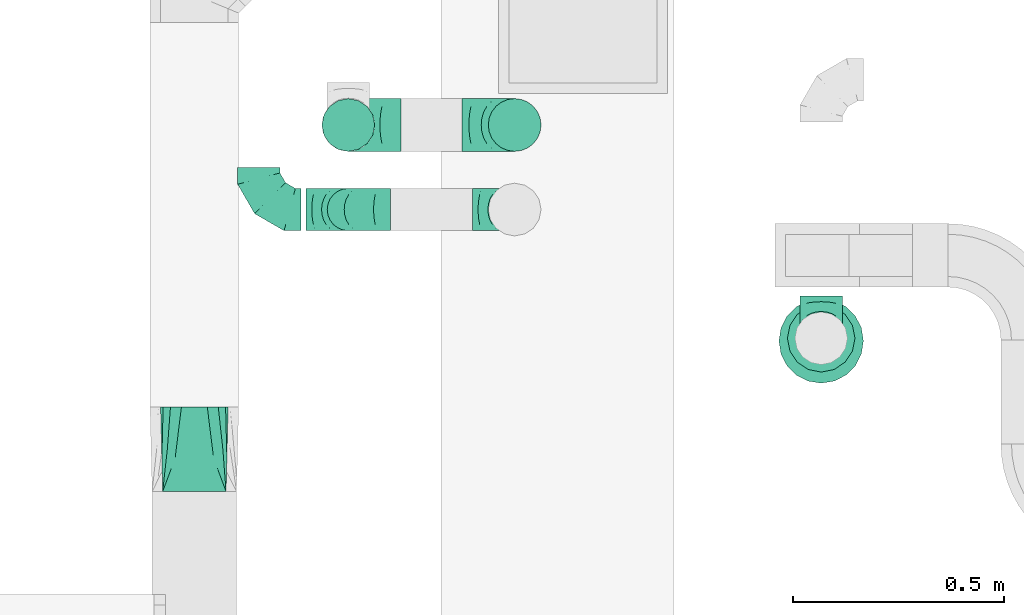
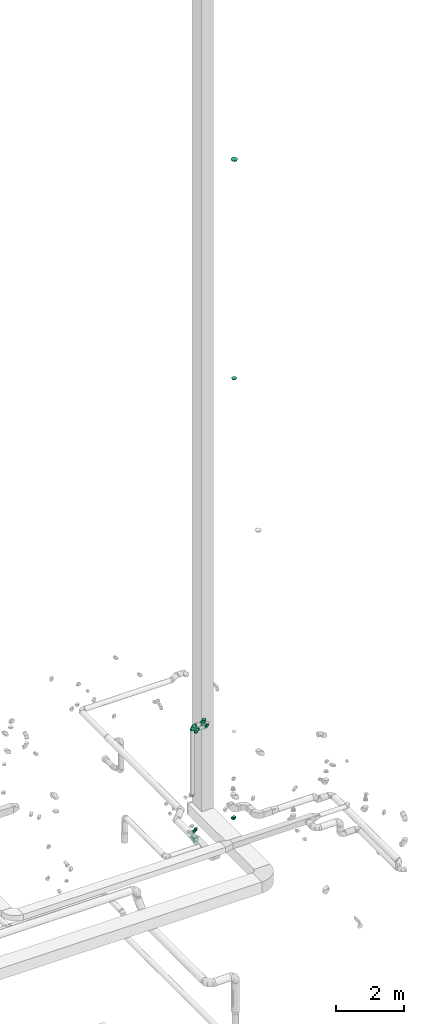
# One storey, part 73 of 97: 11 flow fittings.
"""IFC2X3 building model written with IfcOpenShell, lengths in millimetres."""

import ifcopenshell
import ifcopenshell.guid

model = None  # the IFC model being written
_history = None  # IfcOwnerHistory: only IFC2X3 demands one
_inside = {}  # id of a spatial element -> (the spatial element, [elements in it])
_under = {}  # id of a project, library or spatial element -> (it, [spatial elements below it])
_declared = {}  # id of a project -> (the project, [libraries it declares])
_typed = {}  # id of a type object -> (the type object, [elements of that type])
_made_of = {}  # id of a material, layer set ... -> (it, [elements and type objects made of it])


def new_model(schema):
    """Start an empty IFC model of exactly this schema.

    Asked for "IFC4X3", IfcOpenShell would pick the latest addendum, in which some entities
    have other attributes; the version numbers below select the first issue.
    IFC2X3 requires an IfcOwnerHistory on every rooted entity: one is made here for all.
    """
    global model, _history
    if schema == "IFC4X3":
        model = ifcopenshell.file(schema_version=(4, 3, 0, 0))
    else:
        model = ifcopenshell.file(schema=schema)
    _inside.clear()
    _under.clear()
    _declared.clear()
    _typed.clear()
    _made_of.clear()
    _history = None
    if model.schema == "IFC2X3":
        org = make("IfcOrganization", Name="unknown")
        user = make(
            "IfcPersonAndOrganization",
            ThePerson=make("IfcPerson", FamilyName="unknown"),
            TheOrganization=org,
        )
        app = make(
            "IfcApplication",
            ApplicationDeveloper=org,
            Version="unknown",
            ApplicationFullName="unknown",
            ApplicationIdentifier="unknown",
        )
        _history = make(
            "IfcOwnerHistory",
            OwningUser=user,
            OwningApplication=app,
            ChangeAction="ADDED",
            CreationDate=0,
        )
    return model


def make(cls, **values):
    """One entity of the class cls with the attributes given. An attribute that is None is left unset."""
    return model.create_entity(
        cls, **{name: value for name, value in values.items() if value is not None}
    )


def entity(cls, *values):
    """Any entity or typed value of the class cls, its attributes in the order of the schema. None: left unset."""
    e = model.create_entity(cls)
    for i, value in enumerate(values):
        if value is not None:
            e[i] = value
    return e


def rooted(cls, **values):
    """An entity with a GlobalId (a new one), such as an element, a storey or a relation."""
    return make(cls, GlobalId=ifcopenshell.guid.new(), OwnerHistory=_history, **values)


def si_unit(unit_type, name, prefix=None):
    """IfcSIUnit, for example si_unit("LENGTHUNIT", "METRE", prefix="MILLI")."""
    return make("IfcSIUnit", UnitType=unit_type, Prefix=prefix, Name=name)


def converted_unit(unit_type, name, factor, base, dimensions=None, offset=None):
    """IfcConversionBasedUnit, such as the inch: factor (a typed value) times the base unit."""
    return make(
        "IfcConversionBasedUnit"
        if offset is None
        else "IfcConversionBasedUnitWithOffset",
        ConversionOffset=offset,
        Dimensions=None
        if dimensions is None
        else entity("IfcDimensionalExponents", *dimensions),
        UnitType=unit_type,
        Name=name,
        ConversionFactor=make(
            "IfcMeasureWithUnit", ValueComponent=factor, UnitComponent=base
        ),
    )


def derived_unit(unit_type, elements):
    """IfcDerivedUnit: a product of units, each with its exponent."""
    return make(
        "IfcDerivedUnit",
        Elements=[
            make("IfcDerivedUnitElement", Unit=unit, Exponent=power)
            for unit, power in elements
        ],
        UnitType=unit_type,
    )


def assignment(units):
    """IfcUnitAssignment: the units of a project."""
    return None if units is None else make("IfcUnitAssignment", Units=units)


def point(xyz):
    """IfcCartesianPoint."""
    return None if xyz is None else make("IfcCartesianPoint", Coordinates=xyz)


def direction(xyz):
    """IfcDirection."""
    return None if xyz is None else make("IfcDirection", DirectionRatios=xyz)


def frame(location, z_axis=None, x_axis=None):
    """IfcAxis2Placement3D, a coordinate frame: its origin and axes. An axis left out is left unset."""
    return make(
        "IfcAxis2Placement3D",
        Location=point(location),
        Axis=direction(z_axis),
        RefDirection=direction(x_axis),
    )


def origin():
    """The frame at (0, 0, 0) with its axes left unset."""
    return frame((0.0, 0.0, 0.0))


def place(relative_to, where):
    """IfcLocalPlacement: puts the frame where relative to a parent placement (None: the world)."""
    return make(
        "IfcLocalPlacement", PlacementRelTo=relative_to, RelativePlacement=where
    )


def context(
    kind, dimensions, precision=None, world=None, true_north=None, identifier=None
):
    """IfcGeometricRepresentationContext, for example the 3D "Model" context."""
    return make(
        "IfcGeometricRepresentationContext",
        ContextIdentifier=identifier,
        ContextType=kind,
        CoordinateSpaceDimension=dimensions,
        Precision=precision,
        WorldCoordinateSystem=world,
        TrueNorth=true_north,
    )


def subcontext(parent, identifier, kind, view, scale=None):
    """IfcGeometricRepresentationSubContext, for example "Body" below "Model"."""
    return make(
        "IfcGeometricRepresentationSubContext",
        ContextIdentifier=identifier,
        ContextType=kind,
        ParentContext=parent,
        TargetScale=scale,
        TargetView=view,
    )


def project(units=None, contexts=None):
    """IfcProject with its units and contexts."""
    return rooted(
        "IfcProject",
        Name="project",
        RepresentationContexts=contexts,
        UnitsInContext=assignment(units),
    )


def spatial(cls, under=None, at=None, **own):
    """A site, building, storey or space (cls), placed at a placement, below another one or the project."""
    s = rooted(cls, ObjectPlacement=at, **own)
    if under is not None:
        _under.setdefault(under.id(), (under, []))[1].append(s)
    return s


def faces_of(points, faces, orient=None, outer=None):
    """IfcFace entities. A face is a list of loops; a loop is a list of indices into points, from 0.

    orient and outer hold one flag for each loop. By default every Orientation is true, the
    first loop of a face is its IfcFaceOuterBound and the others are IfcFaceBound.
    """
    made = []
    for i, loops in enumerate(faces):
        bounds = []
        for j, loop in enumerate(loops):
            is_outer = j == 0 if outer is None else outer[i][j]
            bounds.append(
                make(
                    "IfcFaceOuterBound" if is_outer else "IfcFaceBound",
                    Bound=make("IfcPolyLoop", Polygon=[points[k] for k in loop]),
                    Orientation=True if orient is None else orient[i][j],
                )
            )
        made.append(make("IfcFace", Bounds=bounds))
    return made


def faceted_brep(points, faces, orient=None, outer=None, voids=None):
    """IfcFacetedBrep: a solid bounded by flat faces; with voids (closed shells), ...WithVoids."""
    shared = [point(p) for p in points]
    hull = make("IfcClosedShell", CfsFaces=faces_of(shared, faces, orient, outer))
    if voids is None:
        return make("IfcFacetedBrep", Outer=hull)
    return make(
        "IfcFacetedBrepWithVoids",
        Outer=hull,
        Voids=[
            make(cls, CfsFaces=faces_of(shared, fs, o, b)) for cls, fs, o, b in voids
        ],
    )


def shape(context_of_items, identifier, shape_type, items):
    """IfcShapeRepresentation: the items that make up one representation, for example the "Body"."""
    return make(
        "IfcShapeRepresentation",
        ContextOfItems=context_of_items,
        RepresentationIdentifier=identifier,
        RepresentationType=shape_type,
        Items=items,
    )


def source(mapping_origin, context_of_items, identifier, shape_type, items):
    """IfcRepresentationMap: a shape defined once, which mapped items show again and again."""
    return make(
        "IfcRepresentationMap",
        MappingOrigin=mapping_origin,
        MappedRepresentation=shape(context_of_items, identifier, shape_type, items),
    )


def transform(
    local_origin,
    x_axis=None,
    y_axis=None,
    z_axis=None,
    scale=None,
    scale2=None,
    scale3=None,
    uniform=True,
):
    """IfcCartesianTransformationOperator3D, or its non-uniform kind. x_axis, y_axis, z_axis: its Axis1, 2, 3."""
    if uniform:
        return make(
            "IfcCartesianTransformationOperator3D",
            Axis1=direction(x_axis),
            Axis2=direction(y_axis),
            LocalOrigin=point(local_origin),
            Scale=scale,
            Axis3=direction(z_axis),
        )
    return make(
        "IfcCartesianTransformationOperator3DnonUniform",
        Axis1=direction(x_axis),
        Axis2=direction(y_axis),
        LocalOrigin=point(local_origin),
        Scale=scale,
        Axis3=direction(z_axis),
        Scale2=scale2,
        Scale3=scale3,
    )


def mapped(mapping_source, mapping_target):
    """IfcMappedItem: shows the shape of a source again, moved by a transform."""
    return make(
        "IfcMappedItem", MappingSource=mapping_source, MappingTarget=mapping_target
    )


def material(Name=None, Category=None):
    """IfcMaterial."""
    return make("IfcMaterial", Name=Name, Category=Category)


def made_of(thing, what):
    """Note that an element or type object is made of a material, layer set ...; save() writes the relation."""
    if what is not None:
        _made_of.setdefault(what.id(), (what, []))[1].append(thing)
    return thing


def type_object(cls, material=None, **own):
    """A type object (cls), such as IfcWallType, which elements share."""
    return made_of(rooted(cls, **own), material)


def type_shapes(of_type, sources):
    """Give a type object the sources (RepresentationMaps) that its elements show as mapped items."""
    of_type.RepresentationMaps = sources


def element(
    cls,
    number,
    at=None,
    inside=None,
    cuts=None,
    type_object=None,
    material=None,
    context=None,
    identifier="Body",
    shape_type=None,
    held_by="IfcProductDefinitionShape",
    body=None,
    shapes=None,
    **own,
):
    """One element of the class cls, such as IfcWall. Its Tag is "e" and its number.

    at: its placement. inside: the storey or other place that contains it. cuts: it is an
    opening in that element (IfcRelVoidsElement). A single representation is given by context,
    identifier, shape_type and body (its items); several are given by shapes. held_by: the class
    of the entity that holds the representations. save() writes the other relations.
    """
    e = rooted(cls, Tag="e%d" % number, ObjectPlacement=at, **own)
    if body is not None:
        shapes = [shape(context, identifier, shape_type, body)]
    if shapes is not None:
        e.Representation = make(held_by, Representations=shapes)
    if inside is not None:
        _inside.setdefault(inside.id(), (inside, []))[1].append(e)
    if cuts is not None:
        rooted(
            "IfcRelVoidsElement", RelatingBuildingElement=cuts, RelatedOpeningElement=e
        )
    if type_object is not None:
        _typed.setdefault(type_object.id(), (type_object, []))[1].append(e)
    return made_of(e, material)


def aggregate(whole, parts):
    """IfcRelAggregates: a whole, such as a stair, and the parts it consists of."""
    return rooted("IfcRelAggregates", RelatingObject=whole, RelatedObjects=parts)


def save(model, path):
    """Write the relations noted so far, then the file.

    IfcRelAggregates (storeys below a building ...), IfcRelContainedInSpatialStructure (elements
    in a storey), IfcRelDefinesByType, IfcRelAssociatesMaterial and IfcRelDeclares: one each for
    every whole, place, type object, material and project.
    """
    for whole, parts in _under.values():
        aggregate(whole, parts)
    for where, things in _inside.values():
        rooted(
            "IfcRelContainedInSpatialStructure",
            RelatedElements=things,
            RelatingStructure=where,
        )
    for kind, things in _typed.values():
        rooted("IfcRelDefinesByType", RelatedObjects=things, RelatingType=kind)
    for what, things in _made_of.values():
        rooted("IfcRelAssociatesMaterial", RelatedObjects=things, RelatingMaterial=what)
    for by, libraries in _declared.values():
        rooted("IfcRelDeclares", RelatingContext=by, RelatedDefinitions=libraries)
    model.write(path)


model = new_model("IFC2X3")

# Units and contexts
model_context = context("Model", 3, precision=0.01, world=origin(), true_north=direction((6.12303176911189e-17, 1.0)))
body_context = subcontext(model_context, "Body", "Model", "MODEL_VIEW")
ifc_project = project(units=[si_unit("LENGTHUNIT", "METRE", prefix="MILLI"), si_unit("AREAUNIT", "SQUARE_METRE"), si_unit("VOLUMEUNIT", "CUBIC_METRE"), converted_unit("PLANEANGLEUNIT", "DEGREE", entity("IfcRatioMeasure", 0.0174532925199433), si_unit("PLANEANGLEUNIT", "RADIAN"), dimensions=[0, 0, 0, 0, 0, 0, 0]), si_unit("MASSUNIT", "GRAM", prefix="KILO"), derived_unit("MASSDENSITYUNIT", [(si_unit("MASSUNIT", "GRAM", prefix="KILO"), 1), (si_unit("LENGTHUNIT", "METRE"), -3)]), derived_unit("MOMENTOFINERTIAUNIT", [(si_unit("LENGTHUNIT", "METRE"), 4)]), si_unit("TIMEUNIT", "SECOND"), si_unit("FREQUENCYUNIT", "HERTZ"), si_unit("THERMODYNAMICTEMPERATUREUNIT", "DEGREE_CELSIUS"), derived_unit("THERMALTRANSMITTANCEUNIT", [(si_unit("MASSUNIT", "GRAM", prefix="KILO"), 1), (si_unit("THERMODYNAMICTEMPERATUREUNIT", "KELVIN"), -1), (si_unit("TIMEUNIT", "SECOND"), -3)]), derived_unit("VOLUMETRICFLOWRATEUNIT", [(si_unit("LENGTHUNIT", "METRE"), 3), (si_unit("TIMEUNIT", "SECOND"), -1)]), derived_unit("MASSFLOWRATEUNIT", [(si_unit("MASSUNIT", "GRAM", prefix="KILO"), 1), (si_unit("TIMEUNIT", "SECOND"), -1)]), derived_unit("ROTATIONALFREQUENCYUNIT", [(si_unit("TIMEUNIT", "SECOND"), -1)]), si_unit("ELECTRICCURRENTUNIT", "AMPERE"), si_unit("ELECTRICVOLTAGEUNIT", "VOLT"), si_unit("POWERUNIT", "WATT"), si_unit("FORCEUNIT", "NEWTON", prefix="KILO"), si_unit("ILLUMINANCEUNIT", "LUX"), si_unit("LUMINOUSFLUXUNIT", "LUMEN"), si_unit("LUMINOUSINTENSITYUNIT", "CANDELA"), derived_unit("USERDEFINED", [(si_unit("MASSUNIT", "GRAM", prefix="KILO"), -1), (si_unit("LENGTHUNIT", "METRE"), -2), (si_unit("TIMEUNIT", "SECOND"), 3), (si_unit("LUMINOUSFLUXUNIT", "LUMEN"), 1)]), derived_unit("LINEARVELOCITYUNIT", [(si_unit("LENGTHUNIT", "METRE"), 1), (si_unit("TIMEUNIT", "SECOND"), -1)]), si_unit("PRESSUREUNIT", "PASCAL"), derived_unit("USERDEFINED", [(si_unit("LENGTHUNIT", "METRE"), -2), (si_unit("MASSUNIT", "GRAM", prefix="KILO"), 1), (si_unit("TIMEUNIT", "SECOND"), -2)]), derived_unit("LINEARFORCEUNIT", [(si_unit("MASSUNIT", "GRAM", prefix="KILO"), 1), (si_unit("LENGTHUNIT", "METRE"), 1), (si_unit("TIMEUNIT", "SECOND"), -2), (si_unit("LENGTHUNIT", "METRE"), -1)]), derived_unit("PLANARFORCEUNIT", [(si_unit("MASSUNIT", "GRAM", prefix="KILO"), 1), (si_unit("LENGTHUNIT", "METRE"), 1), (si_unit("TIMEUNIT", "SECOND"), -2), (si_unit("LENGTHUNIT", "METRE"), -2)])], contexts=[model_context])

# Site, building, storey
site_placement = place(None, origin())
site = spatial("IfcSite", under=ifc_project, at=site_placement, CompositionType="ELEMENT")
building_placement = place(site_placement, origin())
building = spatial("IfcBuilding", under=site, at=building_placement, CompositionType="ELEMENT")
storey_placement = place(building_placement, frame((0.0, 0.0, -4900.0)))
storey = spatial("IfcBuildingStorey", under=building, at=storey_placement, CompositionType="ELEMENT", Elevation=-4900.0)

# Flow fittings
ifc_material = material()
duct_fitting_type_1 = type_object("IfcDuctFittingType", PredefinedType="NOTDEFINED", material=ifc_material)
shared_shape_1 = source(origin(), body_context, "Body", "Brep", [
    faceted_brep([(40.0, -58.78, -80.9), (40.0, -30.9, -95.11), (40.0, 0.0, -100.0), (40.0, 30.9, -95.11), (40.0, 58.78, -80.9), (40.0, 80.9, -58.78), (40.0, 95.11, -30.9), (40.0, 100.0, 0.0), (40.0, 95.11, 30.9), (40.0, 80.9, 58.78), (40.0, 58.78, 80.9), (40.0, 30.9, 95.11), (40.0, 0.0, 100.0), (40.0, -30.9, 95.11), (40.0, -58.78, 80.9), (40.0, -80.9, 58.78), (40.0, -95.11, 30.9), (40.0, -100.0, 0.0), (40.0, -95.11, -30.9), (40.0, -80.9, -58.78), (0.0, -30.61, -73.91), (0.0, -43.59, -65.24), (0.0, -56.57, -56.57), (0.0, -65.24, -43.59), (0.0, -73.91, -30.61), (0.0, -76.96, -15.31), (0.0, -80.0, 0.0), (0.0, -76.96, 15.31), (0.0, -73.91, 30.61), (0.0, -65.24, 43.59), (0.0, -56.57, 56.57), (0.0, -43.59, 65.24), (0.0, -30.61, 73.91), (0.0, -15.31, 76.96), (0.0, 0.0, 80.0), (0.0, 15.31, 76.96), (0.0, 30.61, 73.91), (0.0, 43.59, 65.24), (0.0, 56.57, 56.57), (0.0, 65.24, 43.59), (0.0, 73.91, 30.61), (0.0, 76.96, 15.31), (0.0, 80.0, 0.0), (0.0, 76.96, -15.31), (0.0, 73.91, -30.61), (0.0, 65.24, -43.59), (0.0, 56.57, -56.57), (0.0, 43.59, -65.24), (0.0, 30.61, -73.91), (0.0, 15.31, -76.96), (0.0, 0.0, -80.0), (0.0, -15.31, -76.96)], [[[0, 1, 2, 3, 4, 5, 6, 7, 8, 9, 10, 11, 12, 13, 14, 15, 16, 17, 18, 19]], [[20, 21, 22, 23, 24, 25, 26, 27, 28, 29, 30, 31, 32, 33, 34, 35, 36, 37, 38, 39, 40, 41, 42, 43, 44, 45, 46, 47, 48, 49, 50, 51]], [[7, 41, 8]], [[40, 9, 8]], [[10, 38, 37, 36]], [[39, 38, 9, 40]], [[11, 36, 35]], [[34, 12, 35]], [[41, 40, 8]], [[10, 36, 11]], [[35, 12, 11]], [[41, 7, 42]], [[38, 10, 9]], [[12, 33, 13]], [[32, 14, 13]], [[15, 30, 29, 28]], [[31, 30, 14, 32]], [[16, 28, 27]], [[26, 17, 27]], [[33, 32, 13]], [[15, 28, 16]], [[27, 17, 16]], [[33, 12, 34]], [[30, 15, 14]], [[17, 25, 18]], [[24, 19, 18]], [[0, 22, 21, 20]], [[23, 22, 19, 24]], [[1, 20, 51]], [[50, 2, 51]], [[25, 24, 18]], [[0, 20, 1]], [[51, 2, 1]], [[25, 17, 26]], [[22, 0, 19]], [[2, 49, 3]], [[48, 4, 3]], [[5, 46, 45, 44]], [[47, 46, 4, 48]], [[6, 44, 43]], [[42, 7, 43]], [[49, 48, 3]], [[5, 44, 6]], [[43, 7, 6]], [[49, 2, 50]], [[46, 5, 4]]]),
])
type_shapes(duct_fitting_type_1, [shared_shape_1])
flow_fitting_1_placement = place(storey_placement, frame((68613.63, 11667.58, 27535.19), z_axis=(-1.0, 0.0, 0.0), x_axis=(0.0, 0.0, 1.0)))
element("IfcFlowFitting", 1, at=flow_fitting_1_placement, inside=storey, type_object=duct_fitting_type_1, material=ifc_material, context=body_context, shape_type="MappedRepresentation", body=[
    mapped(shared_shape_1, transform((0.0, 0.0, 0.0), scale=1.0)),
])
duct_fitting_type_2 = type_object("IfcDuctFittingType", PredefinedType="NOTDEFINED", material=ifc_material)
shared_shape_2 = source(origin(), body_context, "Body", "Brep", [
    faceted_brep([(-100.0, 0.0, -50.0), (-100.0, -12.94, -48.3), (-100.0, -25.0, -43.3), (-100.0, -35.36, -35.36), (-100.0, -43.3, -25.0), (-100.0, -48.3, -12.94), (-100.0, -50.0, 0.0), (-100.0, -48.3, 12.94), (-100.0, -43.3, 25.0), (-100.0, -35.36, 35.36), (-100.0, -25.0, 43.3), (-100.0, -12.94, 48.3), (-100.0, 0.0, 50.0), (-100.0, 12.94, 48.3), (-100.0, 25.0, 43.3), (-100.0, 35.36, 35.36), (-100.0, 43.3, 25.0), (-100.0, 48.3, 12.94), (-100.0, 50.0, 0.0), (-100.0, 48.3, -12.94), (-100.0, 43.3, -25.0), (-100.0, 35.36, -35.36), (-100.0, 25.0, -43.3), (-100.0, 12.94, -48.3), (-76.67, 12.94, 48.3), (-79.9, 25.0, 43.3), (-73.21, 0.0, 50.0), (-82.68, 35.36, 35.36), (-86.15, 48.3, 12.94), (-86.6, 50.0, 0.0), (-84.81, 43.3, 25.0), (-84.81, 43.3, -25.0), (-82.68, 35.36, -35.36), (-86.15, 48.3, -12.94), (-76.67, 12.94, -48.3), (-73.21, 0.0, -50.0), (-79.9, 25.0, -43.3), (-69.74, -12.94, -48.3), (-66.51, -25.0, -43.3), (-63.73, -35.36, -35.36), (-61.6, -43.3, -25.0), (-60.26, -48.3, -12.94), (-59.81, -50.0, 0.0), (-60.26, -48.3, 12.94), (-61.6, -43.3, 25.0), (-63.73, -35.36, 35.36), (-66.51, -25.0, 43.3), (-69.74, -12.94, 48.3), (-36.27, 36.27, 48.3), (-45.1, 45.1, 43.3), (-26.79, 26.79, 50.0), (-52.68, 52.68, 35.36), (-58.49, 58.49, 25.0), (-62.15, 62.15, 12.94), (-63.4, 63.4, 0.0), (-62.15, 62.15, -12.94), (-58.49, 58.49, -25.0), (-52.68, 52.68, -35.36), (-36.27, 36.27, -48.3), (-26.79, 26.79, -50.0), (-45.1, 45.1, -43.3), (-17.32, 17.32, -48.3), (-8.49, 8.49, -43.3), (-0.91, 0.91, -35.36), (4.9, -4.9, -25.0), (8.56, -8.56, -12.94), (9.81, -9.81, 0.0), (8.56, -8.56, 12.94), (4.9, -4.9, 25.0), (-0.91, 0.91, 35.36), (-8.49, 8.49, 43.3), (-17.32, 17.32, 48.3), (-12.94, 76.67, 48.3), (-25.0, 79.9, 43.3), (0.0, 73.21, 50.0), (-35.36, 82.68, 35.36), (-43.3, 84.81, 25.0), (-48.3, 86.15, 12.94), (-50.0, 86.6, 0.0), (-48.3, 86.15, -12.94), (-43.3, 84.81, -25.0), (-35.36, 82.68, -35.36), (-12.94, 76.67, -48.3), (0.0, 73.21, -50.0), (-25.0, 79.9, -43.3), (12.94, 69.74, -48.3), (25.0, 66.51, -43.3), (35.36, 63.73, -35.36), (43.3, 61.6, -25.0), (48.3, 60.26, -12.94), (50.0, 59.81, 0.0), (48.3, 60.26, 12.94), (43.3, 61.6, 25.0), (35.36, 63.73, 35.36), (25.0, 66.51, 43.3), (12.94, 69.74, 48.3), (-12.94, 100.0, -48.3), (-25.0, 100.0, -43.3), (-35.36, 100.0, -35.36), (-43.3, 100.0, -25.0), (-48.3, 100.0, -12.94), (-50.0, 100.0, 0.0), (-48.3, 100.0, 12.94), (-43.3, 100.0, 25.0), (-35.36, 100.0, 35.36), (-25.0, 100.0, 43.3), (-12.94, 100.0, 48.3), (0.0, 100.0, 50.0), (12.94, 100.0, 48.3), (25.0, 100.0, 43.3), (35.36, 100.0, 35.36), (43.3, 100.0, 25.0), (48.3, 100.0, 12.94), (50.0, 100.0, 0.0), (48.3, 100.0, -12.94), (43.3, 100.0, -25.0), (35.36, 100.0, -35.36), (25.0, 100.0, -43.3), (12.94, 100.0, -48.3), (0.0, 100.0, -50.0)], [[[0, 1, 2, 3, 4, 5, 6, 7, 8, 9, 10, 11, 12, 13, 14, 15, 16, 17, 18, 19, 20, 21, 22, 23]], [[24, 25, 14, 13]], [[26, 24, 13, 12]], [[14, 25, 27, 15]], [[28, 29, 18, 17]], [[30, 28, 17, 16]], [[15, 27, 30, 16]], [[20, 31, 32, 21]], [[33, 31, 20, 19]], [[18, 29, 33, 19]], [[34, 35, 0, 23]], [[36, 34, 23, 22]], [[32, 36, 22, 21]], [[2, 1, 37, 38]], [[3, 2, 38, 39]], [[0, 35, 37, 1]], [[5, 4, 40, 41]], [[6, 5, 41, 42]], [[3, 39, 40, 4]], [[6, 42, 43, 7]], [[7, 43, 44, 8]], [[8, 44, 45, 9]], [[10, 46, 47, 11]], [[11, 47, 26, 12]], [[10, 9, 45, 46]], [[48, 49, 25, 24]], [[50, 48, 24, 26]], [[27, 25, 49, 51]], [[52, 53, 28, 30]], [[51, 52, 30, 27]], [[29, 28, 53, 54]], [[55, 56, 31, 33]], [[54, 55, 33, 29]], [[57, 32, 31, 56]], [[58, 59, 35, 34]], [[60, 58, 34, 36]], [[57, 60, 36, 32]], [[37, 35, 59, 61]], [[38, 37, 61, 62]], [[39, 38, 62, 63]], [[41, 40, 64, 65]], [[42, 41, 65, 66]], [[63, 64, 40, 39]], [[43, 42, 66, 67]], [[44, 43, 67, 68]], [[68, 69, 45, 44]], [[46, 45, 69, 70]], [[47, 46, 70, 71]], [[26, 47, 71, 50]], [[72, 73, 49, 48]], [[74, 72, 48, 50]], [[51, 49, 73, 75]], [[76, 77, 53, 52]], [[75, 76, 52, 51]], [[54, 53, 77, 78]], [[79, 80, 56, 55]], [[78, 79, 55, 54]], [[81, 57, 56, 80]], [[82, 83, 59, 58]], [[84, 82, 58, 60]], [[81, 84, 60, 57]], [[61, 59, 83, 85]], [[62, 61, 85, 86]], [[63, 62, 86, 87]], [[65, 64, 88, 89]], [[66, 65, 89, 90]], [[87, 88, 64, 63]], [[67, 66, 90, 91]], [[68, 67, 91, 92]], [[92, 93, 69, 68]], [[70, 69, 93, 94]], [[71, 70, 94, 95]], [[50, 71, 95, 74]], [[96, 97, 98, 99, 100, 101, 102, 103, 104, 105, 106, 107, 108, 109, 110, 111, 112, 113, 114, 115, 116, 117, 118, 119]], [[72, 74, 107, 106]], [[73, 72, 106, 105]], [[75, 73, 105, 104]], [[77, 76, 103, 102]], [[78, 77, 102, 101]], [[75, 104, 103, 76]], [[78, 101, 100, 79]], [[79, 100, 99, 80]], [[80, 99, 98, 81]], [[96, 119, 83, 82]], [[97, 96, 82, 84]], [[84, 81, 98, 97]], [[83, 119, 118, 85]], [[85, 118, 117, 86]], [[86, 117, 116, 87]], [[88, 115, 114, 89]], [[89, 114, 113, 90]], [[87, 116, 115, 88]], [[91, 90, 113, 112]], [[92, 91, 112, 111]], [[93, 92, 111, 110]], [[95, 94, 109, 108]], [[74, 95, 108, 107]], [[110, 109, 94, 93]]]),
])
type_shapes(duct_fitting_type_2, [shared_shape_2])
for number, where, z_axis, x_axis in (
    (2, (68613.63, 11673.78, 4000.0), (1.0, 0.0, 0.0), (0.0, 0.0, -1.0)),
    (3, (67282.28, 11978.54, 3790.0), (0.0, 0.0, 1.0), (0.0, -1.0, 0.0)),
    (4, (67494.25, 11978.54, 3790.0), (0.0, -1.0, 0.0), (1.0, 0.0, 0.0)),
    (5, (67494.25, 11978.54, 7400.0), (0.0, 1.0, 0.0), (0.0, 0.0, 1.0)),
    (6, (67888.0, 11978.54, 7400.0), (0.0, -1.0, 0.0), (1.0, 0.0, 0.0)),
):
    element("IfcFlowFitting", number, at=place(storey_placement, frame(where, z_axis=z_axis, x_axis=x_axis)), inside=storey, type_object=duct_fitting_type_2, material=ifc_material, context=body_context, shape_type="MappedRepresentation", body=[
        mapped(shared_shape_2, transform((0.0, 0.0, 0.0), scale=1.0)),
    ])
duct_fitting_type_3 = type_object("IfcDuctFittingType", PredefinedType="NOTDEFINED", material=ifc_material)
shared_shape_3 = source(origin(), body_context, "Body", "Brep", [
    faceted_brep([(-125.0, 0.0, -62.5), (-125.0, -16.18, -60.37), (-125.0, -31.25, -54.13), (-125.0, -44.19, -44.19), (-125.0, -54.13, -31.25), (-125.0, -60.37, -16.18), (-125.0, -62.5, 0.0), (-125.0, -60.37, 16.18), (-125.0, -54.13, 31.25), (-125.0, -44.19, 44.19), (-125.0, -31.25, 54.13), (-125.0, -16.18, 60.37), (-125.0, 0.0, 62.5), (-125.0, 16.18, 60.37), (-125.0, 31.25, 54.13), (-125.0, 44.19, 44.19), (-125.0, 54.13, 31.25), (-125.0, 60.37, 16.18), (-125.0, 62.5, 0.0), (-125.0, 60.37, -16.18), (-125.0, 54.13, -31.25), (-125.0, 44.19, -44.19), (-125.0, 31.25, -54.13), (-125.0, 16.18, -60.37), (-95.84, 16.18, 60.37), (-99.88, 31.25, 54.13), (-91.51, 0.0, 62.5), (-103.35, 44.19, 44.19), (-107.68, 60.37, 16.18), (-108.25, 62.5, 0.0), (-106.01, 54.13, 31.25), (-106.01, 54.13, -31.25), (-103.35, 44.19, -44.19), (-107.68, 60.37, -16.18), (-95.84, 16.18, -60.37), (-91.51, 0.0, -62.5), (-99.88, 31.25, -54.13), (-87.17, -16.18, -60.37), (-83.13, -31.25, -54.13), (-79.66, -44.19, -44.19), (-77.0, -54.13, -31.25), (-75.33, -60.37, -16.18), (-74.76, -62.5, 0.0), (-75.33, -60.37, 16.18), (-77.0, -54.13, 31.25), (-79.66, -44.19, 44.19), (-83.13, -31.25, 54.13), (-87.17, -16.18, 60.37), (-45.34, 45.34, 60.37), (-56.37, 56.37, 54.13), (-33.49, 33.49, 62.5), (-65.85, 65.85, 44.19), (-73.12, 73.12, 31.25), (-77.69, 77.69, 16.18), (-79.25, 79.25, 0.0), (-77.69, 77.69, -16.18), (-73.12, 73.12, -31.25), (-65.85, 65.85, -44.19), (-45.34, 45.34, -60.37), (-33.49, 33.49, -62.5), (-56.37, 56.37, -54.13), (-21.65, 21.65, -60.37), (-10.62, 10.62, -54.13), (-1.14, 1.14, -44.19), (6.13, -6.13, -31.25), (10.7, -10.7, -16.18), (12.26, -12.26, 0.0), (10.7, -10.7, 16.18), (6.13, -6.13, 31.25), (-1.14, 1.14, 44.19), (-10.62, 10.62, 54.13), (-21.65, 21.65, 60.37), (-16.18, 95.84, 60.37), (-31.25, 99.88, 54.13), (0.0, 91.51, 62.5), (-44.19, 103.35, 44.19), (-54.13, 106.01, 31.25), (-60.37, 107.68, 16.18), (-62.5, 108.25, 0.0), (-60.37, 107.68, -16.18), (-54.13, 106.01, -31.25), (-44.19, 103.35, -44.19), (-16.18, 95.84, -60.37), (0.0, 91.51, -62.5), (-31.25, 99.88, -54.13), (16.18, 87.17, -60.37), (31.25, 83.13, -54.13), (44.19, 79.66, -44.19), (54.13, 77.0, -31.25), (60.37, 75.33, -16.18), (62.5, 74.76, 0.0), (60.37, 75.33, 16.18), (54.13, 77.0, 31.25), (44.19, 79.66, 44.19), (31.25, 83.13, 54.13), (16.18, 87.17, 60.37), (-16.18, 125.0, -60.37), (-31.25, 125.0, -54.13), (-44.19, 125.0, -44.19), (-54.13, 125.0, -31.25), (-60.37, 125.0, -16.18), (-62.5, 125.0, 0.0), (-60.37, 125.0, 16.18), (-54.13, 125.0, 31.25), (-44.19, 125.0, 44.19), (-31.25, 125.0, 54.13), (-16.18, 125.0, 60.37), (0.0, 125.0, 62.5), (16.18, 125.0, 60.37), (31.25, 125.0, 54.13), (44.19, 125.0, 44.19), (54.13, 125.0, 31.25), (60.37, 125.0, 16.18), (62.5, 125.0, 0.0), (60.37, 125.0, -16.18), (54.13, 125.0, -31.25), (44.19, 125.0, -44.19), (31.25, 125.0, -54.13), (16.18, 125.0, -60.37), (0.0, 125.0, -62.5)], [[[0, 1, 2, 3, 4, 5, 6, 7, 8, 9, 10, 11, 12, 13, 14, 15, 16, 17, 18, 19, 20, 21, 22, 23]], [[24, 25, 14, 13]], [[26, 24, 13, 12]], [[14, 25, 27, 15]], [[28, 29, 18, 17]], [[30, 28, 17, 16]], [[15, 27, 30, 16]], [[20, 31, 32, 21]], [[33, 31, 20, 19]], [[18, 29, 33, 19]], [[34, 35, 0, 23]], [[36, 34, 23, 22]], [[21, 32, 36, 22]], [[1, 0, 35, 37]], [[2, 1, 37, 38]], [[38, 39, 3, 2]], [[5, 4, 40, 41]], [[6, 5, 41, 42]], [[39, 40, 4, 3]], [[6, 42, 43, 7]], [[7, 43, 44, 8]], [[45, 9, 8, 44]], [[9, 45, 46, 10]], [[10, 46, 47, 11]], [[26, 12, 11, 47]], [[48, 49, 25, 24]], [[50, 48, 24, 26]], [[27, 25, 49, 51]], [[52, 53, 28, 30]], [[51, 52, 30, 27]], [[29, 28, 53, 54]], [[55, 56, 31, 33]], [[54, 55, 33, 29]], [[57, 32, 31, 56]], [[58, 59, 35, 34]], [[60, 58, 34, 36]], [[57, 60, 36, 32]], [[37, 35, 59, 61]], [[38, 37, 61, 62]], [[39, 38, 62, 63]], [[41, 40, 64, 65]], [[42, 41, 65, 66]], [[63, 64, 40, 39]], [[43, 42, 66, 67]], [[44, 43, 67, 68]], [[68, 69, 45, 44]], [[46, 45, 69, 70]], [[47, 46, 70, 71]], [[26, 47, 71, 50]], [[72, 73, 49, 48]], [[74, 72, 48, 50]], [[51, 49, 73, 75]], [[76, 77, 53, 52]], [[75, 76, 52, 51]], [[54, 53, 77, 78]], [[79, 80, 56, 55]], [[78, 79, 55, 54]], [[81, 57, 56, 80]], [[82, 83, 59, 58]], [[84, 82, 58, 60]], [[81, 84, 60, 57]], [[61, 59, 83, 85]], [[62, 61, 85, 86]], [[63, 62, 86, 87]], [[65, 64, 88, 89]], [[66, 65, 89, 90]], [[87, 88, 64, 63]], [[67, 66, 90, 91]], [[68, 67, 91, 92]], [[92, 93, 69, 68]], [[70, 69, 93, 94]], [[71, 70, 94, 95]], [[50, 71, 95, 74]], [[96, 97, 98, 99, 100, 101, 102, 103, 104, 105, 106, 107, 108, 109, 110, 111, 112, 113, 114, 115, 116, 117, 118, 119]], [[72, 74, 107, 106]], [[73, 72, 106, 105]], [[75, 73, 105, 104]], [[77, 76, 103, 102]], [[78, 77, 102, 101]], [[75, 104, 103, 76]], [[78, 101, 100, 79]], [[79, 100, 99, 80]], [[80, 99, 98, 81]], [[96, 119, 83, 82]], [[97, 96, 82, 84]], [[84, 81, 98, 97]], [[83, 119, 118, 85]], [[85, 118, 117, 86]], [[116, 87, 86, 117]], [[88, 115, 114, 89]], [[89, 114, 113, 90]], [[115, 88, 87, 116]], [[91, 90, 113, 112]], [[92, 91, 112, 111]], [[111, 110, 93, 92]], [[95, 94, 109, 108]], [[74, 95, 108, 107]], [[110, 109, 94, 93]]]),
])
type_shapes(duct_fitting_type_3, [shared_shape_3])
for number, where, z_axis, x_axis in (
    (7, (67494.25, 12178.74, 7400.0), (0.0, 1.0, 0.0), (0.0, 0.0, 1.0)),
    (8, (67888.0, 12178.74, 7400.0), (0.0, -1.0, 0.0), (1.0, 0.0, 0.0)),
):
    element("IfcFlowFitting", number, at=place(storey_placement, frame(where, z_axis=z_axis, x_axis=x_axis)), inside=storey, type_object=duct_fitting_type_3, material=ifc_material, context=body_context, shape_type="MappedRepresentation", body=[
        mapped(shared_shape_3, transform((0.0, 0.0, 0.0), scale=1.0)),
    ])
duct_fitting_type_4 = type_object("IfcDuctFittingType", PredefinedType="NOTDEFINED", material=ifc_material)
shared_shape_4 = source(origin(), body_context, "Body", "Brep", [
    faceted_brep([(35.0, 0.0, -80.0), (35.0, 12.81, -77.45), (35.0, 30.61, -73.91), (35.0, 43.59, -65.24), (35.0, 56.57, -56.57), (35.0, 65.24, -43.59), (35.0, 73.91, -30.61), (35.0, 76.96, -15.31), (35.0, 80.0, 0.0), (35.0, 77.45, 12.81), (35.0, 73.91, 30.61), (35.0, 65.24, 43.59), (35.0, 56.57, 56.57), (35.0, 43.59, 65.24), (35.0, 30.61, 73.91), (35.0, 15.31, 76.96), (35.0, 0.0, 80.0), (35.0, -12.81, 77.45), (35.0, -30.61, 73.91), (35.0, -43.59, 65.24), (35.0, -56.57, 56.57), (35.0, -65.24, 43.59), (35.0, -73.91, 30.61), (35.0, -76.96, 15.31), (35.0, -80.0, 0.0), (35.0, -77.45, -12.81), (35.0, -73.91, -30.61), (35.0, -65.24, -43.59), (35.0, -56.57, -56.57), (35.0, -43.59, -65.24), (35.0, -30.61, -73.91), (35.0, -15.31, -76.96), (0.0, -23.92, -57.74), (0.0, -34.06, -50.97), (0.0, -44.19, -44.19), (0.0, -50.97, -34.06), (0.0, -57.74, -23.92), (0.0, -60.12, -11.96), (0.0, -62.5, 0.0), (0.0, -60.12, 11.96), (0.0, -57.74, 23.92), (0.0, -50.97, 34.06), (0.0, -44.19, 44.19), (0.0, -34.06, 50.97), (0.0, -23.92, 57.74), (0.0, -11.96, 60.12), (0.0, 0.0, 62.5), (0.0, 11.96, 60.12), (0.0, 23.92, 57.74), (0.0, 34.06, 50.97), (0.0, 44.19, 44.19), (0.0, 50.97, 34.06), (0.0, 57.74, 23.92), (0.0, 60.12, 11.96), (0.0, 62.5, 0.0), (0.0, 60.12, -11.96), (0.0, 57.74, -23.92), (0.0, 50.97, -34.06), (0.0, 44.19, -44.19), (0.0, 34.06, -50.97), (0.0, 23.92, -57.74), (0.0, 11.96, -60.12), (0.0, 0.0, -62.5), (0.0, -11.96, -60.12)], [[[0, 1, 2, 3, 4, 5, 6, 7, 8, 9, 10, 11, 12, 13, 14, 15, 16, 17, 18, 19, 20, 21, 22, 23, 24, 25, 26, 27, 28, 29, 30, 31]], [[32, 33, 34, 35, 36, 37, 38, 39, 40, 41, 42, 43, 44, 45, 46, 47, 48, 49, 50, 51, 52, 53, 54, 55, 56, 57, 58, 59, 60, 61, 62, 63]], [[10, 9, 8, 54, 53, 52]], [[11, 10, 52, 51, 50, 12]], [[48, 14, 13, 12, 50, 49]], [[46, 16, 15, 14, 48, 47]], [[18, 17, 16, 46, 45, 44]], [[19, 18, 44, 43, 42, 20]], [[40, 22, 21, 20, 42, 41]], [[38, 24, 23, 22, 40, 39]], [[26, 25, 24, 38, 37, 36]], [[27, 26, 36, 35, 34, 28]], [[32, 30, 29, 28, 34, 33]], [[62, 0, 31, 30, 32, 63]], [[2, 1, 0, 62, 61, 60]], [[3, 2, 60, 59, 58, 4]], [[56, 6, 5, 4, 58, 57]], [[54, 8, 7, 6, 56, 55]]]),
])
type_shapes(duct_fitting_type_4, [shared_shape_4])
flow_fitting_2_placement = place(storey_placement, frame((68613.63, 11673.8, 19725.2), z_axis=(1.0, 0.0, 0.0), x_axis=(0.0, -0.000796479721370696, 0.999999682809976)))
element("IfcFlowFitting", 9, at=flow_fitting_2_placement, inside=storey, type_object=duct_fitting_type_4, material=ifc_material, context=body_context, shape_type="MappedRepresentation", body=[
    mapped(shared_shape_4, transform((0.0, 0.0, 0.0), scale=1.0)),
])
duct_fitting_type_5 = type_object("IfcDuctFittingType", PredefinedType="NOTDEFINED", material=ifc_material)
shared_shape_5 = source(origin(), body_context, "Body", "Brep", [
    faceted_brep([(200.0, 30.61, 73.91), (200.0, 22.87, 75.45), (200.0, 15.12, 76.99), (200.0, 11.34, 77.74), (200.0, 7.56, 78.5), (200.0, 0.0, 80.0), (200.0, -7.56, 78.5), (200.0, -15.12, 76.99), (200.0, -18.99, 76.22), (200.0, -22.87, 75.45), (200.0, -30.61, 73.91), (200.0, -37.1, 69.57), (200.0, -43.59, 65.24), (200.0, -50.08, 60.9), (200.0, -56.57, 56.57), (200.0, -60.9, 50.08), (200.0, -65.24, 43.59), (200.0, -69.57, 37.1), (200.0, -73.91, 30.61), (200.0, -75.45, 22.87), (200.0, -76.99, 15.12), (200.0, -77.74, 11.34), (200.0, -78.5, 7.56), (200.0, -80.0, 0.0), (200.0, -78.5, -7.56), (200.0, -76.99, -15.12), (200.0, -76.22, -18.99), (200.0, -75.45, -22.87), (200.0, -73.91, -30.61), (200.0, -69.57, -37.1), (200.0, -65.24, -43.59), (200.0, -60.9, -50.08), (200.0, -56.57, -56.57), (200.0, -50.08, -60.9), (200.0, -43.59, -65.24), (200.0, -37.1, -69.57), (200.0, -30.61, -73.91), (200.0, -22.87, -75.45), (200.0, -15.12, -76.99), (200.0, -11.34, -77.74), (200.0, -7.56, -78.5), (200.0, 0.0, -80.0), (200.0, 7.56, -78.5), (200.0, 15.12, -76.99), (200.0, 18.99, -76.22), (200.0, 22.87, -75.45), (200.0, 30.61, -73.91), (200.0, 37.1, -69.57), (200.0, 43.59, -65.24), (200.0, 50.08, -60.9), (200.0, 56.57, -56.57), (200.0, 60.9, -50.08), (200.0, 65.24, -43.59), (200.0, 69.57, -37.1), (200.0, 73.91, -30.61), (200.0, 75.45, -22.87), (200.0, 76.99, -15.12), (200.0, 77.74, -11.34), (200.0, 78.5, -7.56), (200.0, 80.0, 0.0), (200.0, 78.5, 7.56), (200.0, 76.99, 15.12), (200.0, 76.22, 18.99), (200.0, 75.45, 22.87), (200.0, 73.91, 30.61), (200.0, 69.57, 37.1), (200.0, 65.24, 43.59), (200.0, 60.9, 50.08), (200.0, 56.57, 56.57), (200.0, 50.08, 60.9), (200.0, 43.59, 65.24), (200.0, 37.1, 69.57), (0.0, -75.0, 75.0), (0.0, 75.0, 75.0), (0.0, 75.0, -75.0), (0.0, -75.0, -75.0), (52.06, -55.48, 76.3), (78.09, -45.72, 76.95), (176.03, -8.99, 79.4), (152.06, -17.98, 78.8), (128.09, -26.97, 78.2), (104.11, -35.96, 77.6), (100.0, -67.44, 64.02), (78.09, -76.95, 45.72), (104.11, -77.6, 35.96), (128.09, -78.2, 26.97), (152.06, -78.8, 17.98), (164.04, -79.1, 13.48), (176.03, -79.4, 8.99), (26.03, -75.65, 65.24), (52.06, -76.3, 55.48), (26.03, -65.24, 75.65), (26.03, -75.65, -65.24), (52.06, -76.3, -55.48), (78.09, -76.95, -45.72), (104.11, -77.6, -35.96), (128.09, -78.2, -26.97), (152.06, -78.8, -17.98), (176.03, -79.4, -8.99), (100.0, -64.02, -67.44), (78.09, -45.72, -76.95), (104.11, -35.96, -77.6), (128.09, -26.97, -78.2), (152.06, -17.98, -78.8), (164.04, -13.48, -79.1), (176.03, -8.99, -79.4), (26.03, -65.24, -75.65), (52.06, -55.48, -76.3), (26.03, 65.24, -75.65), (52.06, 55.48, -76.3), (78.09, 45.72, -76.95), (104.11, 35.96, -77.6), (128.09, 26.97, -78.2), (152.06, 17.98, -78.8), (176.03, 8.99, -79.4), (100.0, 67.44, -64.02), (78.09, 76.95, -45.72), (104.11, 77.6, -35.96), (128.09, 78.2, -26.97), (152.06, 78.8, -17.98), (164.04, 79.1, -13.48), (176.03, 79.4, -8.99), (26.03, 75.65, -65.24), (52.06, 76.3, -55.48), (26.03, 75.65, 65.24), (52.06, 76.3, 55.48), (78.09, 76.95, 45.72), (104.11, 77.6, 35.96), (128.09, 78.2, 26.97), (152.06, 78.8, 17.98), (176.03, 79.4, 8.99), (100.0, 64.02, 67.44), (78.09, 45.72, 76.95), (104.11, 35.96, 77.6), (128.09, 26.97, 78.2), (152.06, 17.98, 78.8), (164.04, 13.48, 79.1), (176.03, 8.99, 79.4), (26.03, 65.24, 75.65), (52.06, 55.48, 76.3)], [[[0, 1, 2, 3, 4, 5, 6, 7, 8, 9, 10, 11, 12, 13, 14, 15, 16, 17, 18, 19, 20, 21, 22, 23, 24, 25, 26, 27, 28, 29, 30, 31, 32, 33, 34, 35, 36, 37, 38, 39, 40, 41, 42, 43, 44, 45, 46, 47, 48, 49, 50, 51, 52, 53, 54, 55, 56, 57, 58, 59, 60, 61, 62, 63, 64, 65, 66, 67, 68, 69, 70, 71]], [[72, 73, 74, 75]], [[76, 12, 77]], [[12, 11, 10, 77]], [[78, 79, 80, 81, 77, 10, 9, 8, 7, 6, 5]], [[13, 82, 14]], [[20, 19, 18, 83, 84, 85, 86, 87, 88, 23, 22, 21]], [[82, 72, 89]], [[82, 15, 14]], [[83, 16, 90]], [[91, 72, 82]], [[18, 17, 16, 83]], [[90, 16, 15]], [[15, 82, 89]], [[90, 15, 89]], [[76, 13, 12]], [[13, 76, 91]], [[82, 13, 91]], [[88, 87, 86, 85, 84, 83, 90, 89, 72, 75, 92, 93, 94, 95, 96, 97, 98, 23]], [[93, 30, 94]], [[30, 29, 28, 94]], [[98, 97, 96, 95, 94, 28, 27, 26, 25, 24, 23]], [[31, 99, 32]], [[38, 37, 36, 100, 101, 102, 103, 104, 105, 41, 40, 39]], [[99, 75, 106]], [[99, 33, 32]], [[100, 34, 107]], [[92, 75, 99]], [[36, 35, 34, 100]], [[107, 34, 33]], [[33, 99, 106]], [[107, 33, 106]], [[93, 31, 30]], [[31, 93, 92]], [[99, 31, 92]], [[105, 104, 103, 102, 101, 100, 107, 106, 75, 74, 108, 109, 110, 111, 112, 113, 114, 41]], [[109, 48, 110]], [[48, 47, 46, 110]], [[114, 113, 112, 111, 110, 46, 45, 44, 43, 42, 41]], [[49, 115, 50]], [[56, 55, 54, 116, 117, 118, 119, 120, 121, 59, 58, 57]], [[115, 74, 122]], [[115, 51, 50]], [[116, 52, 123]], [[108, 74, 115]], [[54, 53, 52, 116]], [[123, 52, 51]], [[51, 115, 122]], [[123, 51, 122]], [[109, 49, 48]], [[49, 109, 108]], [[115, 49, 108]], [[74, 73, 124, 125, 126, 127, 128, 129, 130, 59, 121, 120, 119, 118, 117, 116, 123, 122]], [[125, 66, 126]], [[66, 65, 64, 126]], [[130, 129, 128, 127, 126, 64, 63, 62, 61, 60, 59]], [[67, 131, 68]], [[2, 1, 0, 132, 133, 134, 135, 136, 137, 5, 4, 3]], [[131, 73, 138]], [[131, 69, 68]], [[132, 70, 139]], [[124, 73, 131]], [[0, 71, 70, 132]], [[139, 70, 69]], [[69, 131, 138]], [[139, 69, 138]], [[125, 67, 66]], [[67, 125, 124]], [[131, 67, 124]], [[73, 72, 91, 76, 77, 81, 80, 79, 78, 5, 137, 136, 135, 134, 133, 132, 139, 138]]]),
])
type_shapes(duct_fitting_type_5, [shared_shape_5])
flow_fitting_3_placement = place(storey_placement, frame((67129.73, 11311.06, 4000.0), z_axis=(0.0, 0.0, 1.0), x_axis=(0.0, 1.0, 0.0)))
element("IfcFlowFitting", 10, at=flow_fitting_3_placement, inside=storey, type_object=duct_fitting_type_5, material=ifc_material, context=body_context, shape_type="MappedRepresentation", body=[
    mapped(shared_shape_5, transform((0.0, 0.0, 0.0), scale=1.0)),
])
duct_fitting_type_6 = type_object("IfcDuctFittingType", PredefinedType="NOTDEFINED", material=ifc_material)
shared_shape_6 = source(origin(), body_context, "Body", "Brep", [
    faceted_brep([(25.0, 0.0, -62.5), (25.0, 12.45, -60.02), (25.0, 23.92, -57.74), (25.0, 34.06, -50.97), (25.0, 44.19, -44.19), (25.0, 50.97, -34.06), (25.0, 57.74, -23.92), (25.0, 60.02, -12.45), (25.0, 62.5, 0.0), (25.0, 60.02, 12.45), (25.0, 57.74, 23.92), (25.0, 50.97, 34.06), (25.0, 44.19, 44.19), (25.0, 34.06, 50.97), (25.0, 23.92, 57.74), (25.0, 12.45, 60.02), (25.0, 0.0, 62.5), (25.0, -12.45, 60.02), (25.0, -23.92, 57.74), (25.0, -34.06, 50.97), (25.0, -44.19, 44.19), (25.0, -50.97, 34.06), (25.0, -57.74, 23.92), (25.0, -60.02, 12.45), (25.0, -62.5, 0.0), (25.0, -60.02, -12.45), (25.0, -57.74, -23.92), (25.0, -50.97, -34.06), (25.0, -44.19, -44.19), (25.0, -34.06, -50.97), (25.0, -23.92, -57.74), (25.0, -12.45, -60.02), (0.0, -19.13, -46.19), (0.0, -27.24, -40.77), (0.0, -35.36, -35.36), (0.0, -40.77, -27.24), (0.0, -46.19, -19.13), (0.0, -48.1, -9.57), (0.0, -50.0, 0.0), (0.0, -48.1, 9.57), (0.0, -46.19, 19.13), (0.0, -40.77, 27.24), (0.0, -35.36, 35.36), (0.0, -27.24, 40.77), (0.0, -19.13, 46.19), (0.0, -9.57, 48.1), (0.0, 0.0, 50.0), (0.0, 9.57, 48.1), (0.0, 19.13, 46.19), (0.0, 27.24, 40.77), (0.0, 35.36, 35.36), (0.0, 40.77, 27.24), (0.0, 46.19, 19.13), (0.0, 48.1, 9.57), (0.0, 50.0, 0.0), (0.0, 48.1, -9.57), (0.0, 46.19, -19.13), (0.0, 40.77, -27.24), (0.0, 35.36, -35.36), (0.0, 27.24, -40.77), (0.0, 19.13, -46.19), (0.0, 9.57, -48.1), (0.0, 0.0, -50.0), (0.0, -9.57, -48.1)], [[[0, 1, 2, 3, 4, 5, 6, 7, 8, 9, 10, 11, 12, 13, 14, 15, 16, 17, 18, 19, 20, 21, 22, 23, 24, 25, 26, 27, 28, 29, 30, 31]], [[32, 33, 34, 35, 36, 37, 38, 39, 40, 41, 42, 43, 44, 45, 46, 47, 48, 49, 50, 51, 52, 53, 54, 55, 56, 57, 58, 59, 60, 61, 62, 63]], [[52, 10, 9, 8, 54, 53]], [[51, 50, 12, 11, 10, 52]], [[47, 46, 16, 15, 14, 48]], [[49, 48, 14, 13, 12, 50]], [[44, 18, 17, 16, 46, 45]], [[43, 42, 20, 19, 18, 44]], [[39, 38, 24, 23, 22, 40]], [[41, 40, 22, 21, 20, 42]], [[36, 26, 25, 24, 38, 37]], [[35, 34, 28, 27, 26, 36]], [[63, 62, 0, 31, 30, 32]], [[33, 32, 30, 29, 28, 34]], [[60, 2, 1, 0, 62, 61]], [[59, 58, 4, 3, 2, 60]], [[55, 54, 8, 7, 6, 56]], [[57, 56, 6, 5, 4, 58]]]),
])
type_shapes(duct_fitting_type_6, [shared_shape_6])
flow_fitting_4_placement = place(storey_placement, frame((67494.25, 12178.74, 4927.66), z_axis=(0.0, 1.0, 0.0), x_axis=(0.0, 0.0, 1.0)))
element("IfcFlowFitting", 11, at=flow_fitting_4_placement, inside=storey, type_object=duct_fitting_type_6, material=ifc_material, context=body_context, shape_type="MappedRepresentation", body=[
    mapped(shared_shape_6, transform((0.0, 0.0, 0.0), scale=1.0)),
])

save(model, "model.ifc")
